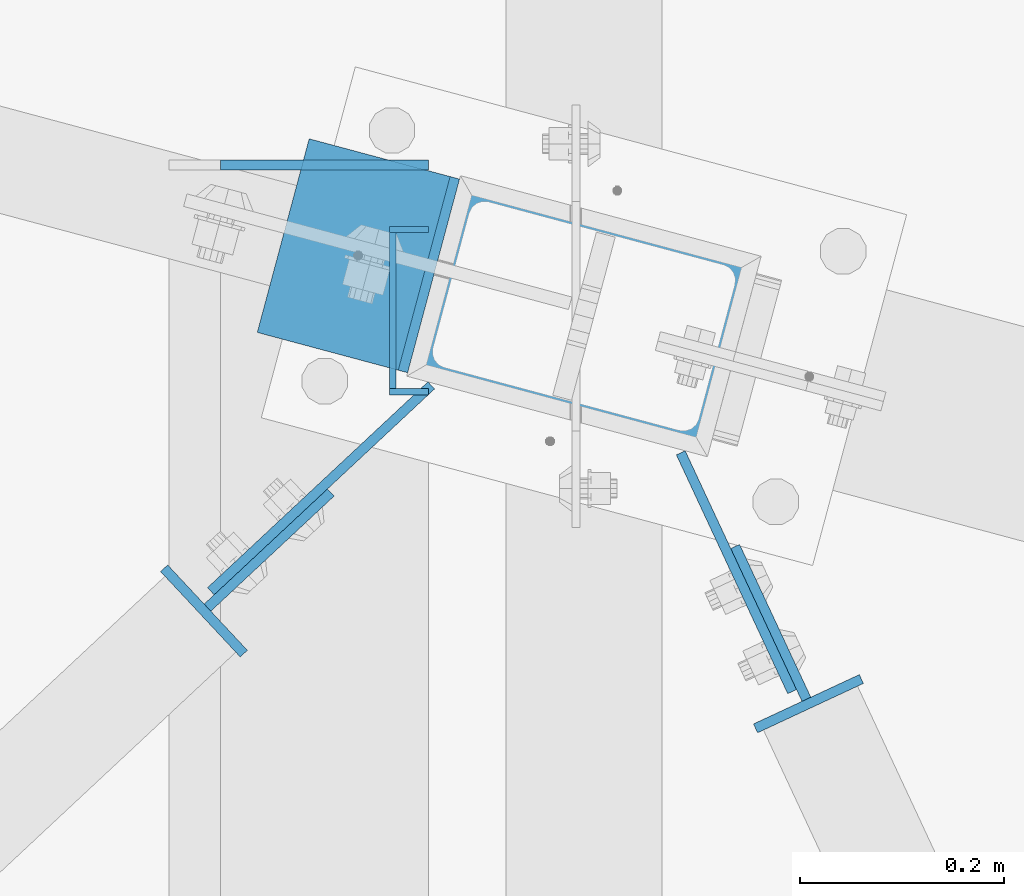
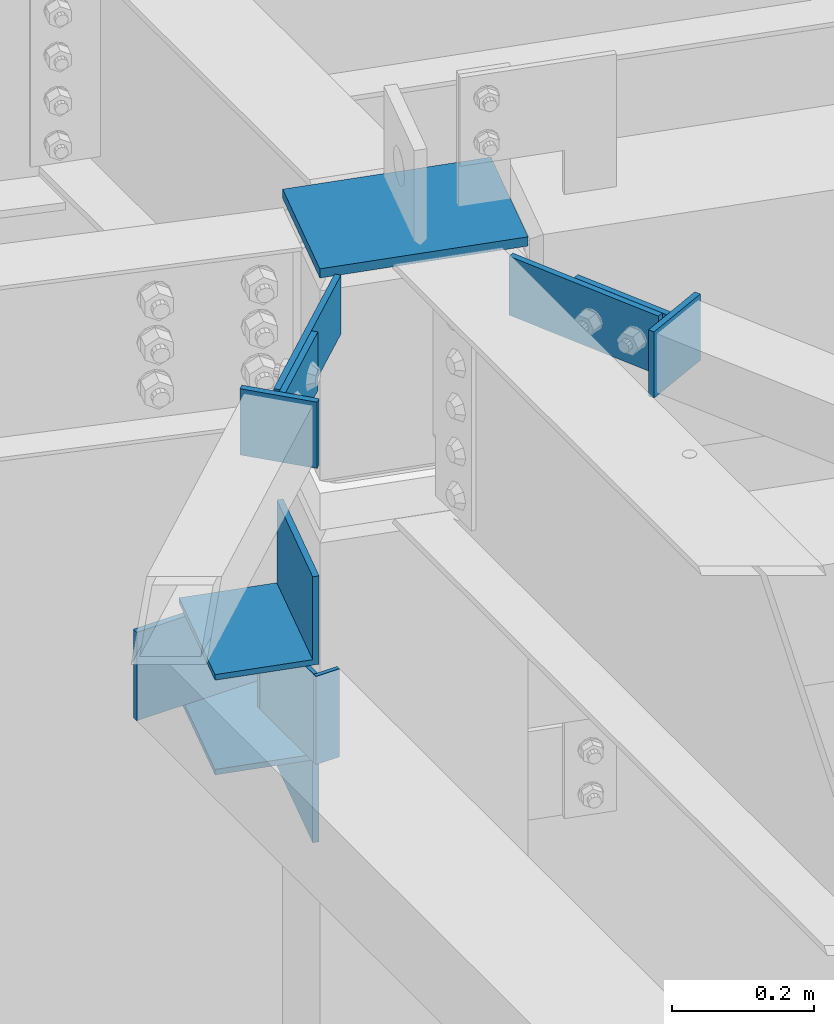
# One storey, part 1369 of 1763: 13 beams, 4 elements without a shape of their own.
"""IFC2X3 building model written with IfcOpenShell, lengths in millimetres."""

from ifc_helpers import new_model, si_unit, frame, origin_with_axes, place, context, subcontext, project, spatial, faceted_brep, material, type_object, element, aggregate, save


model = new_model("IFC2X3")

# Units and contexts
model_context = context("Model", 3, precision=1e-05, world=origin_with_axes())
body_context = subcontext(model_context, "Body", "Model", "MODEL_VIEW")
ifc_project = project(units=[si_unit("LENGTHUNIT", "METRE", prefix="MILLI"), si_unit("AREAUNIT", "SQUARE_METRE"), si_unit("VOLUMEUNIT", "CUBIC_METRE"), si_unit("MASSUNIT", "GRAM", prefix="KILO"), si_unit("TIMEUNIT", "SECOND"), si_unit("PLANEANGLEUNIT", "RADIAN"), si_unit("SOLIDANGLEUNIT", "STERADIAN"), si_unit("THERMODYNAMICTEMPERATUREUNIT", "DEGREE_CELSIUS"), si_unit("LUMINOUSINTENSITYUNIT", "LUMEN")], contexts=[model_context])

# Site, building, storey
site_placement = place(None, origin_with_axes())
site = spatial("IfcSite", under=ifc_project, at=site_placement, CompositionType="ELEMENT")
building_placement = place(site_placement, origin_with_axes())
building = spatial("IfcBuilding", under=site, at=building_placement, Name="Undefined", CompositionType="ELEMENT")
storey_placement = place(building_placement, origin_with_axes())
storey = spatial("IfcBuildingStorey", under=building, at=storey_placement, Name="Undefined", CompositionType="ELEMENT", Elevation=0.0)

# Assembly, beam
assembly_1_placement = place(storey_placement, origin_with_axes())
assembly_1 = element("IfcElementAssembly", 1, at=assembly_1_placement, inside=storey, Name="H. BRACE", AssemblyPlace="NOTDEFINED", PredefinedType="RIGID_FRAME")
ifc_material_1 = material(Name="STEEL/A36")
beam_type_1 = type_object("IfcBeamType", PredefinedType="NOTDEFINED")
beam_1_placement = place(assembly_1_placement, frame((-39980.4723130829, 66452.444394941, 12433.3), z_axis=(0.730932691702631, 0.682449558722362, 0.0), x_axis=(0.0, 0.0, -1.0)))
beam_1 = element("IfcBeam", 2, at=beam_1_placement, type_object=beam_type_1, material=ifc_material_1, Name="PLATE", context=body_context, shape_type="Brep", body=[
    faceted_brep([(0.0, 4.7625000001417, -82.5500000001048), (0.0, 4.76249999986885, 82.5500000001339), (101.599999999999, 4.76249999986885, 82.5500000001339), (101.599999999999, 4.7625000001417, -82.5500000001048), (0.0, -4.76250000014352, 82.5500000001193), (101.599999999999, -4.76250000014352, 82.5500000001193), (0.0, -4.76249999987067, -82.5500000001193), (101.599999999999, -4.76249999987067, -82.5500000001193)], [[[0, 1, 2, 3]], [[1, 4, 5, 2]], [[4, 6, 7, 5]], [[6, 0, 3, 7]], [[5, 7, 3, 2]], [[6, 4, 1, 0]]]),
])

# Assembly, beams
assembly_2_placement = place(storey_placement, origin_with_axes())
assembly_2 = element("IfcElementAssembly", 3, at=assembly_2_placement, inside=storey, Name="COLUMN", AssemblyPlace="NOTDEFINED", PredefinedType="RIGID_FRAME")
beam_2_placement = place(assembly_2_placement, frame((-39929.6690564218, 66512.9091416838, 12433.3), z_axis=(0.730932691702631, 0.682449558722362, 0.0), x_axis=(0.0, 0.0, -1.0)))
beam_2 = element("IfcBeam", 4, at=beam_2_placement, type_object=beam_type_1, material=ifc_material_1, Name="PLATE", context=body_context, shape_type="Brep", body=[
    faceted_brep([(0.0, 4.76250000012806, -147.637499999755), (0.0, 4.76249999988067, 147.637499999777), (101.599999999999, 4.76249999988067, 147.637499999777), (101.599999999999, 4.76250000012806, -147.637499999755), (0.0, -4.7625000001135, 147.63749999977), (101.599999999999, -4.7625000001135, 147.63749999977), (0.0, -4.76249999986612, -147.637499999762), (101.599999999999, -4.76249999986612, -147.637499999762)], [[[0, 1, 2, 3]], [[1, 4, 5, 2]], [[4, 6, 7, 5]], [[6, 0, 3, 7]], [[5, 7, 3, 2]], [[6, 4, 1, 0]]]),
])
beam_3_placement = place(assembly_2_placement, frame((-39522.9906958647, 66430.7453574727, 12422.1875), z_axis=(-0.422551799059311, 0.906338776127194, 0.0), x_axis=(0.0, 0.0, -1.0)))
beam_3 = element("IfcBeam", 5, at=beam_3_placement, type_object=beam_type_1, material=ifc_material_1, Name="PLATE", context=body_context, shape_type="Brep", body=[
    faceted_brep([(0.0, 4.76250000051004, -128.984500000428), (0.0, 4.76249999947322, 128.98450000037), (101.599999999999, 4.76249999947322, 128.98450000037), (101.599999999999, 4.76250000051004, -128.984500000428), (0.0, -4.76250000051368, 128.984500000428), (101.599999999999, -4.76250000051368, 128.984500000428), (0.0, -4.76249999947686, -128.98450000037), (101.599999999999, -4.76249999947686, -128.98450000037)], [[[0, 1, 2, 3]], [[1, 4, 5, 2]], [[4, 6, 7, 5]], [[6, 0, 3, 7]], [[5, 7, 3, 2]], [[6, 4, 1, 0]]]),
])

# Assembly, beam
assembly_3_placement = place(storey_placement, origin_with_axes())
assembly_3 = element("IfcElementAssembly", 6, at=assembly_3_placement, inside=storey, Name="H. BRACE", AssemblyPlace="NOTDEFINED", PredefinedType="RIGID_FRAME")
beam_4_placement = place(assembly_3_placement, frame((-39489.3647251642, 66381.1620374592, 12422.1875), z_axis=(-0.422551799059311, 0.906338776127194, 0.0), x_axis=(0.0, 0.0, -1.0)))
beam_4 = element("IfcBeam", 7, at=beam_4_placement, type_object=beam_type_1, material=ifc_material_1, Name="PLATE", context=body_context, shape_type="Brep", body=[
    faceted_brep([(0.0, 4.76249999983474, -82.5385000002425), (0.0, 4.7625000001949, 82.5385000002425), (101.599999999999, 4.7625000001949, 82.5385000002425), (101.599999999999, 4.76249999983474, -82.5385000002425), (0.0, -4.76249999983202, 82.538500000257), (101.599999999999, -4.76249999983202, 82.538500000257), (0.0, -4.76250000019945, -82.5385000002134), (101.599999999999, -4.76250000019945, -82.5385000002134)], [[[0, 1, 2, 3]], [[1, 4, 5, 2]], [[4, 6, 7, 5]], [[6, 0, 3, 7]], [[5, 7, 3, 2]], [[6, 4, 1, 0]]]),
])

assembly_4_placement = place(storey_placement, origin_with_axes())
assembly_4 = element("IfcElementAssembly", 8, at=assembly_4_placement, inside=storey, Name="BEAM", AssemblyPlace="NOTDEFINED", PredefinedType="RIGID_FRAME")
beam_type_2 = type_object("IfcBeamType", PredefinedType="NOTDEFINED")
beam_5_placement = place(assembly_4_placement, frame((-39824.6896174484, 66829.384375, 11684.0), z_axis=(0.0, 0.0, -1.0), x_axis=(-1.0, 0.0, 0.0)))
beam_5 = element("IfcBeam", 9, at=beam_5_placement, type_object=beam_type_2, material=ifc_material_1, Name="PLATE", context=body_context, shape_type="Brep", body=[
    faceted_brep([(0.0, 4.76250000000073, -76.1999999999971), (0.0, 4.76250000000073, 76.1999969482422), (203.199981689453, 4.76249999999982, 76.1999969482422), (203.199999999997, 4.76249999999709, -76.2000000000007), (0.0, -4.76250000000073, 76.1999969482422), (203.199981689453, -4.76249999999982, 76.1999969482422), (0.0, -4.76250000000073, -76.1999999999971), (203.199999999997, -4.76249999999709, -76.2000000000007)], [[[0, 1, 2, 3]], [[4, 5, 2, 1]], [[4, 6, 7, 5]], [[6, 0, 3, 7]], [[5, 7, 3, 2]], [[6, 4, 1, 0]]]),
])

# Beam
beam_type_3 = type_object("IfcBeamType", PredefinedType="NOTDEFINED")
beam_6_placement = place(assembly_1_placement, frame((-40044.291873727, 66392.8580178453, 12439.65), z_axis=(-0.682449558722358, 0.730932691702635, 0.0), x_axis=(0.0, 0.0, -1.0)))
beam_6 = element("IfcBeam", 10, at=beam_6_placement, type_object=beam_type_3, material=ifc_material_1, Name="PLATE", context=body_context, shape_type="Brep", body=[
    faceted_brep([(0.0, 4.76249999989523, -57.1500000001702), (0.0, 4.76250000014261, 57.1500000001565), (114.299999999999, 4.76250000014261, 57.1500000001565), (114.299999999999, 4.76249999989523, -57.1500000001702), (0.0, -4.76249999988067, 57.1500000001784), (114.299999999999, -4.76249999988067, 57.1500000001784), (0.0, -4.76250000012806, -57.150000000152), (114.299999999999, -4.76250000012806, -57.150000000152)], [[[0, 1, 2, 3]], [[1, 4, 5, 2]], [[4, 6, 7, 5]], [[6, 0, 3, 7]], [[5, 7, 3, 2]], [[6, 4, 1, 0]]]),
])

aggregate(assembly_1, [beam_1, beam_6])

beam_7_placement = place(assembly_3_placement, frame((-39452.4763755873, 66302.0395686751, 12428.5375), z_axis=(-0.906338774799721, -0.422551801906631, 0.0), x_axis=(0.0, 0.0, -1.0)))
beam_7 = element("IfcBeam", 11, at=beam_7_placement, type_object=beam_type_3, material=ifc_material_1, Name="PLATE", context=body_context, shape_type="Brep", body=[
    faceted_brep([(0.0, 4.76249999989523, -57.1500000001702), (0.0, 4.76250000014261, 57.1500000001565), (114.299999999999, 4.76250000014261, 57.1500000001565), (114.299999999999, 4.76249999989523, -57.1500000001702), (0.0, -4.76249999988067, 57.1500000001784), (114.299999999999, -4.76249999988067, 57.1500000001784), (0.0, -4.76250000012806, -57.150000000152), (114.299999999999, -4.76250000012806, -57.150000000152)], [[[0, 1, 2, 3]], [[1, 4, 5, 2]], [[4, 6, 7, 5]], [[6, 0, 3, 7]], [[5, 7, 3, 2]], [[6, 4, 1, 0]]]),
])

aggregate(assembly_3, [beam_4, beam_7])

beam_type_4 = type_object("IfcBeamType", PredefinedType="NOTDEFINED")
beam_8_placement = place(assembly_4_placement, frame((-39862.7900631379, 66766.2855858731, 11684.0), z_axis=(0.0, 0.0, 1.0), x_axis=(0.999999999999168, -1.29000000004882e-06, 0.0)))
beam_8 = element("IfcBeam", 12, at=beam_8_placement, type_object=beam_type_4, material=ifc_material_1, Name="PLATE", context=body_context, shape_type="Brep", body=[
    faceted_brep([(0.0, 3.17500000001746, -76.2000000000007), (-1.51339918375015e-09, 3.17499999999927, 76.1999969482422), (38.1004398547084, 3.17500000023574, 76.2000000000007), (38.1004398547084, 3.17500000023574, -76.2000000000007), (-1.51339918375015e-09, -3.17499999999927, 76.1999969482422), (38.1004398547011, -3.17499999978463, 76.2000000000007), (0.0, -3.17500000000291, -76.2000000000007), (38.1004398547011, -3.17499999978463, -76.2000000000007)], [[[0, 1, 2, 3]], [[1, 4, 5, 2]], [[4, 6, 7, 5]], [[6, 0, 3, 7]], [[5, 7, 3, 2]], [[6, 4, 1, 0]]]),
])

beam_9_placement = place(assembly_4_placement, frame((-39862.7899946085, 66607.5356041812, 11684.0), z_axis=(0.0, 0.0, 1.0), x_axis=(0.999999999999168, -1.29000000004882e-06, 0.0)))
beam_9 = element("IfcBeam", 13, at=beam_9_placement, type_object=beam_type_4, material=ifc_material_1, Name="PLATE", context=body_context, shape_type="Brep", body=[
    faceted_brep([(0.0, 3.17500000001746, -76.2000000000007), (-1.51339918375015e-09, 3.17499999999927, 76.1999969482422), (38.1004398547084, 3.17500000023574, 76.2000000000007), (38.1004398547084, 3.17500000023574, -76.2000000000007), (-1.51339918375015e-09, -3.17499999999927, 76.1999969482422), (38.1004398547011, -3.17499999978463, 76.2000000000007), (0.0, -3.17500000000291, -76.2000000000007), (38.1004398547011, -3.17499999978463, -76.2000000000007)], [[[0, 1, 2, 3]], [[1, 4, 5, 2]], [[4, 6, 7, 5]], [[6, 0, 3, 7]], [[5, 7, 3, 2]], [[6, 4, 1, 0]]]),
])

beam_type_5 = type_object("IfcBeamType", PredefinedType="NOTDEFINED")
beam_10_placement = place(assembly_4_placement, frame((-39859.6146174484, 66610.7105250082, 11684.0), z_axis=(0.0, 0.0, 1.0), x_axis=(0.0, 1.0, 0.0)))
beam_10 = element("IfcBeam", 14, at=beam_10_placement, type_object=beam_type_5, material=ifc_material_1, Name="PLATE", context=body_context, shape_type="Brep", body=[
    faceted_brep([(0.0, 3.17500000001746, -76.2000000000007), (-1.51339918375015e-09, 3.17499999999927, 76.1999969482422), (152.399990844715, 3.17500000000291, 76.2000000000007), (152.399990844715, 3.17500000000291, -76.2000000000007), (-1.51339918375015e-09, -3.17499999999927, 76.1999969482422), (152.399990844715, -3.17500000000291, 76.2000000000007), (0.0, -3.17500000000291, -76.2000000000007), (152.399990844715, -3.17500000000291, -76.2000000000007)], [[[0, 1, 2, 3]], [[1, 4, 5, 2]], [[4, 6, 7, 5]], [[6, 0, 3, 7]], [[5, 7, 3, 2]], [[6, 4, 1, 0]]]),
])

aggregate(assembly_4, [beam_8, beam_9, beam_10, beam_5])

beam_type_6 = type_object("IfcBeamType", Name="L6X6X3/8", PredefinedType="NOTDEFINED")
beam_11_placement = place(assembly_2_placement, frame((-39867.6946627387, 66835.3658384328, 11837.987), z_axis=(0.0, 0.0, 1.0), x_axis=(-0.258865912030778, -0.965913267114844, 3.00823476209188e-08)))
beam_11 = element("IfcBeam", 15, at=beam_11_placement, type_object=beam_type_6, material=ifc_material_1, Name="ANGLE", ObjectType="L6X6X3/8", context=body_context, shape_type="Brep", body=[
    faceted_brep([(9.09494701772928e-13, 76.2000000000007, -76.2000000000844), (0.0, 76.2000000000007, 76.2000000000771), (196.277705575609, 76.1999999998807, 76.2000000000007), (196.277705575609, 76.1999999998807, -76.2000000000007), (0.0, 66.6749999999993, 76.2000000000007), (196.27770557555, 66.6749999998719, 76.2000000000007), (0.0, 66.6749999999993, -66.6749999999993), (196.27770557555, 66.6749999998719, -66.6749999999993), (0.0, -76.2000000000007, -66.6749999999993), (196.277705574626, -76.2000000003973, -66.6749999999993), (9.09494701772928e-13, -76.2000000000007, -76.2000000000844), (196.277705574626, -76.2000000003973, -76.2000000000007)], [[[0, 1, 2, 3]], [[1, 4, 5, 2]], [[4, 6, 7, 5]], [[6, 8, 9, 7]], [[8, 10, 11, 9]], [[10, 0, 3, 11]], [[5, 7, 9, 11, 3, 2]], [[10, 8, 6, 4, 1, 0]]]),
])

beam_12_placement = place(assembly_2_placement, frame((-39918.504270004, 66645.7785985776, 11531.6), z_axis=(0.0, 0.0, -1.0), x_axis=(0.25886591203079, 0.965913267114842, 0.0)))
beam_12 = element("IfcBeam", 16, at=beam_12_placement, type_object=beam_type_6, material=ifc_material_1, Name="ANGLE", ObjectType="L6X6X3/8", context=body_context, shape_type="Brep", body=[
    faceted_brep([(9.09494701772928e-13, 76.2000000000007, -76.2000000000844), (0.0, 76.2000000000007, 76.2000000000771), (196.277705575609, 76.1999999998807, 76.2000000000007), (196.277705575609, 76.1999999998807, -76.2000000000007), (0.0, 66.6749999999993, 76.2000000000007), (196.27770557555, 66.6749999998719, 76.2000000000007), (0.0, 66.6749999999993, -66.6749999999993), (196.27770557555, 66.6749999998719, -66.6749999999993), (0.0, -76.2000000000007, -66.6749999999993), (196.277705574626, -76.2000000003973, -66.6749999999993), (9.09494701772928e-13, -76.2000000000007, -76.2000000000844), (196.277705574626, -76.2000000003973, -76.2000000000007)], [[[0, 1, 2, 3]], [[1, 4, 5, 2]], [[4, 6, 7, 5]], [[6, 8, 9, 7]], [[8, 10, 11, 9]], [[10, 0, 3, 11]], [[5, 7, 9, 11, 3, 2]], [[10, 8, 6, 4, 1, 0]]]),
])

ifc_material_2 = material(Name="STEEL/A572-50")
beam_type_7 = type_object("IfcBeamType", PredefinedType="NOTDEFINED")
beam_13_placement = place(assembly_2_placement, frame((-39525.0844363286, 66641.9514021727, 12438.0625), z_axis=(0.25886591203079, 0.965913267114842, 0.0), x_axis=(-0.965913267114846, 0.258865912030774, 0.0)))
beam_13 = element("IfcBeam", 17, at=beam_13_placement, type_object=beam_type_7, material=ifc_material_2, Name="PLATE", context=body_context, shape_type="Brep", body=[
    faceted_brep([(-5.82076609134674e-11, 7.9375, -101.599999999991), (0.0, 7.9375, 101.599998474121), (304.799999999937, 7.9375, 101.599999999809), (304.799999999814, 7.9375, -101.60000000018), (0.0, -7.9375, 101.599998474121), (304.799999999937, -7.9375, 101.599999999809), (-5.82076609134674e-11, -7.9375, -101.599999999991), (304.799999999814, -7.9375, -101.60000000018)], [[[0, 1, 2, 3]], [[1, 4, 5, 2]], [[4, 6, 7, 5]], [[6, 0, 3, 7]], [[5, 7, 3, 2]], [[6, 4, 1, 0]]]),
])

aggregate(assembly_2, [beam_11, beam_2, beam_13, beam_3, beam_12])

save(model, "model.ifc")
